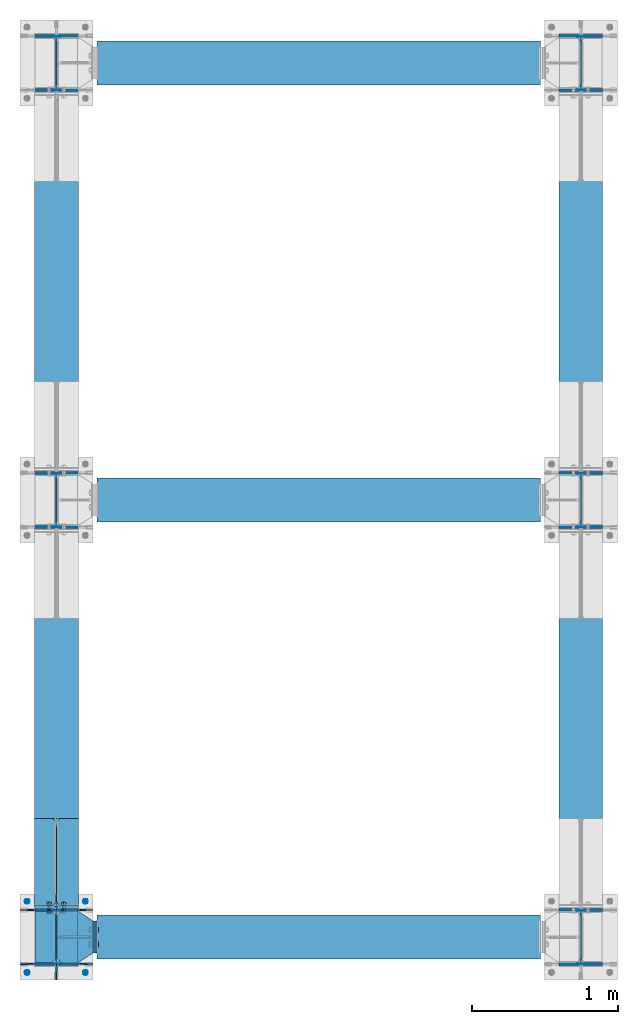
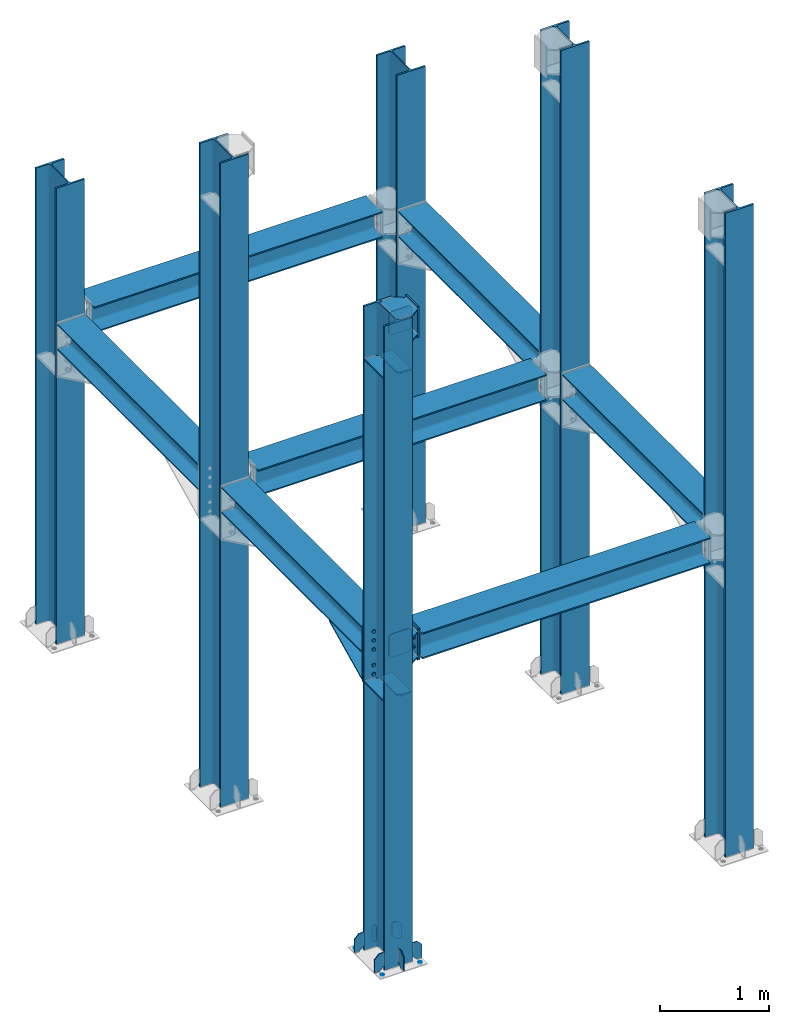
# One storey, part 1 of 23: 21 discrete accessories, 7 beams, 6 columns, 4 mechanical fasteners, 13 elements without a shape of their own.
"""IFC2X3 building model written with IfcOpenShell, lengths in millimetres."""

from ifc_helpers import new_model, si_unit, frame, origin_with_axes, origin_2d_with_axis, place, context, subcontext, project, spatial, polyline, circle, i_section, outline, extrude, clip, halfspace, source, transform, mapped, material, type_object, element, aggregate, save


model = new_model("IFC2X3")

# Units and contexts
model_context = context("Model", 3, precision=1e-05, world=origin_with_axes())
body_context = subcontext(model_context, "Body", "Model", "MODEL_VIEW")
ifc_project = project(units=[si_unit("LENGTHUNIT", "METRE", prefix="MILLI"), si_unit("AREAUNIT", "SQUARE_METRE"), si_unit("VOLUMEUNIT", "CUBIC_METRE"), si_unit("MASSUNIT", "GRAM", prefix="KILO"), si_unit("TIMEUNIT", "SECOND"), si_unit("PLANEANGLEUNIT", "RADIAN"), si_unit("SOLIDANGLEUNIT", "STERADIAN"), si_unit("THERMODYNAMICTEMPERATUREUNIT", "DEGREE_CELSIUS"), si_unit("LUMINOUSINTENSITYUNIT", "LUMEN")], contexts=[model_context])

# Site, building, storey
site_placement = place(None, origin_with_axes())
site = spatial("IfcSite", under=ifc_project, at=site_placement, CompositionType="ELEMENT")
building_placement = place(site_placement, origin_with_axes())
building = spatial("IfcBuilding", under=site, at=building_placement, Name="Edificio", CompositionType="ELEMENT")
storey_placement = place(building_placement, origin_with_axes())
storey = spatial("IfcBuildingStorey", under=building, at=storey_placement, Name="Livello 1", CompositionType="ELEMENT", Elevation=0.0)

# Assembly, column
assembly_1_placement = place(storey_placement, origin_with_axes())
assembly_1 = element("IfcElementAssembly", 1, at=assembly_1_placement, inside=storey, Name="COLUMN", AssemblyPlace="NOTDEFINED", PredefinedType="RIGID_FRAME")
ifc_material_1 = material(Name="STEEL/S235JR")
column_type = type_object("IfcColumnType", Name="HEA400", PredefinedType="NOTDEFINED")
column_1_placement = place(assembly_1_placement, frame((3600.0, 6000.0, 0.0), z_axis=(0.0, 0.0, 1.0), x_axis=(0.0, 1.0, 0.0)))
column_1 = element("IfcColumn", 2, at=column_1_placement, type_object=column_type, material=ifc_material_1, Name="COLUMN", ObjectType="HEA400", context=body_context, shape_type="Clipping", body=[
    clip(clip(extrude(i_section(OverallWidth=300.0, OverallDepth=390.0, WebThickness=11.0, FlangeThickness=19.0, FilletRadius=27.0, at=origin_2d_with_axis()), frame((0.0, 0.0, 5102.11580360386), z_axis=(0.0, 0.0, -1.0), x_axis=(0.0, 1.0, 0.0)), (0.0, 0.0, 1.0), 5092.12), halfspace(frame((-1000.0, 0.0, 5102.11580360386), z_axis=(0.0, 0.0, 1.0), x_axis=(0.0, 1.0, 0.0)), False)), halfspace(frame((-195.0, 0.0, 10.0), z_axis=(0.0, 0.0, 1.0), x_axis=(0.0, 1.0, 0.0)), True)),
])
aggregate(assembly_1, [column_1])

assembly_2_placement = place(storey_placement, origin_with_axes())
assembly_2 = element("IfcElementAssembly", 3, at=assembly_2_placement, inside=storey, Name="COLUMN", AssemblyPlace="NOTDEFINED", PredefinedType="RIGID_FRAME")
column_2_placement = place(assembly_2_placement, frame((0.0, 6000.0, 0.0), z_axis=(0.0, 0.0, 1.0), x_axis=(0.0, 1.0, 0.0)))
column_2 = element("IfcColumn", 4, at=column_2_placement, type_object=column_type, material=ifc_material_1, Name="COLUMN", ObjectType="HEA400", context=body_context, shape_type="Clipping", body=[
    clip(clip(extrude(i_section(OverallWidth=300.0, OverallDepth=390.0, WebThickness=11.0, FlangeThickness=19.0, FilletRadius=27.0, at=origin_2d_with_axis()), frame((0.0, 0.0, 5102.11580360386), z_axis=(0.0, 0.0, -1.0), x_axis=(0.0, 1.0, 0.0)), (0.0, 0.0, 1.0), 5092.12), halfspace(frame((-1000.0, 0.0, 5102.11580360386), z_axis=(0.0, 0.0, 1.0), x_axis=(0.0, 1.0, 0.0)), False)), halfspace(frame((-195.0, 0.0, 10.0), z_axis=(0.0, 0.0, 1.0), x_axis=(0.0, 1.0, 0.0)), True)),
])
aggregate(assembly_2, [column_2])

assembly_3_placement = place(storey_placement, origin_with_axes())
assembly_3 = element("IfcElementAssembly", 5, at=assembly_3_placement, inside=storey, Name="COLUMN", AssemblyPlace="NOTDEFINED", PredefinedType="RIGID_FRAME")
column_3_placement = place(assembly_3_placement, frame((3600.0, 3000.0, 0.0), z_axis=(0.0, 0.0, 1.0), x_axis=(0.0, 1.0, 0.0)))
column_3 = element("IfcColumn", 6, at=column_3_placement, type_object=column_type, material=ifc_material_1, Name="COLUMN", ObjectType="HEA400", context=body_context, shape_type="Clipping", body=[
    clip(extrude(i_section(OverallWidth=300.0, OverallDepth=390.0, WebThickness=11.0, FlangeThickness=19.0, FilletRadius=27.0, at=origin_2d_with_axis()), frame((0.0, 0.0, 7200.0), z_axis=(0.0, 0.0, -1.0), x_axis=(0.0, 1.0, 0.0)), (0.0, 0.0, 1.0), 7190.0), halfspace(frame((-195.0, 0.0, 10.0), z_axis=(0.0, 0.0, 1.0), x_axis=(0.0, 1.0, 0.0)), True)),
])
aggregate(assembly_3, [column_3])

assembly_4_placement = place(storey_placement, origin_with_axes())
assembly_4 = element("IfcElementAssembly", 7, at=assembly_4_placement, inside=storey, Name="COLUMN", AssemblyPlace="NOTDEFINED", PredefinedType="RIGID_FRAME")
column_4_placement = place(assembly_4_placement, frame((0.0, 3000.0, 0.0), z_axis=(0.0, 0.0, 1.0), x_axis=(0.0, 1.0, 0.0)))
column_4 = element("IfcColumn", 8, at=column_4_placement, type_object=column_type, material=ifc_material_1, Name="COLUMN", ObjectType="HEA400", context=body_context, shape_type="Clipping", body=[
    clip(extrude(i_section(OverallWidth=300.0, OverallDepth=390.0, WebThickness=11.0, FlangeThickness=19.0, FilletRadius=27.0, at=origin_2d_with_axis()), frame((0.0, 0.0, 7200.0), z_axis=(0.0, 0.0, -1.0), x_axis=(0.0, 1.0, 0.0)), (0.0, 0.0, 1.0), 7190.0), halfspace(frame((-195.0, 0.0, 10.0), z_axis=(0.0, 0.0, 1.0), x_axis=(0.0, 1.0, 0.0)), True)),
])
aggregate(assembly_4, [column_4])

assembly_5_placement = place(storey_placement, origin_with_axes())
assembly_5 = element("IfcElementAssembly", 9, at=assembly_5_placement, inside=storey, Name="COLUMN", AssemblyPlace="NOTDEFINED", PredefinedType="RIGID_FRAME")
column_5_placement = place(assembly_5_placement, frame((3600.0, 0.0, 0.0), z_axis=(0.0, 0.0, 1.0), x_axis=(0.0, 1.0, 0.0)))
column_5 = element("IfcColumn", 10, at=column_5_placement, type_object=column_type, material=ifc_material_1, Name="COLUMN", ObjectType="HEA400", context=body_context, shape_type="Clipping", body=[
    clip(extrude(i_section(OverallWidth=300.0, OverallDepth=390.0, WebThickness=11.0, FlangeThickness=19.0, FilletRadius=27.0, at=origin_2d_with_axis()), frame((0.0, 0.0, 7200.0), z_axis=(0.0, 0.0, -1.0), x_axis=(0.0, 1.0, 0.0)), (0.0, 0.0, 1.0), 7190.0), halfspace(frame((-195.0, 0.0, 10.0), z_axis=(0.0, 0.0, 1.0), x_axis=(0.0, 1.0, 0.0)), True)),
])
aggregate(assembly_5, [column_5])

assembly_6_placement = place(storey_placement, origin_with_axes())
assembly_6 = element("IfcElementAssembly", 11, at=assembly_6_placement, inside=storey, Name="COLUMN", AssemblyPlace="NOTDEFINED", PredefinedType="RIGID_FRAME")
column_6_placement = place(assembly_6_placement, frame((0.0, 0.0, 0.0), z_axis=(0.0, 0.0, 1.0), x_axis=(0.0, 1.0, 0.0)))
column_6 = element("IfcColumn", 12, at=column_6_placement, type_object=column_type, material=ifc_material_1, Name="COLUMN", ObjectType="HEA400", context=body_context, shape_type="Clipping", body=[
    clip(extrude(i_section(OverallWidth=300.0, OverallDepth=390.0, WebThickness=11.0, FlangeThickness=19.0, FilletRadius=27.0, at=origin_2d_with_axis()), frame((0.0, 0.0, 7200.0), z_axis=(0.0, 0.0, -1.0), x_axis=(0.0, 1.0, 0.0)), (0.0, 0.0, 1.0), 7190.0), halfspace(frame((-195.0, 0.0, 10.0), z_axis=(0.0, 0.0, 1.0), x_axis=(0.0, 1.0, 0.0)), True)),
])

# Assembly, beam
assembly_7_placement = place(storey_placement, origin_with_axes())
assembly_7 = element("IfcElementAssembly", 13, at=assembly_7_placement, inside=storey, Name="BEAM", AssemblyPlace="NOTDEFINED", PredefinedType="RIGID_FRAME")
beam_type = type_object("IfcBeamType", Name="HEA300", PredefinedType="NOTDEFINED")
beam_1_placement = place(assembly_7_placement, frame((0.0, 3000.0, 3455.0), z_axis=(0.0, 0.0, 1.0), x_axis=(0.0, -1.0, 0.0)))
beam_1 = element("IfcBeam", 14, at=beam_1_placement, type_object=beam_type, material=ifc_material_1, Name="BEAM", ObjectType="HEA300", context=body_context, shape_type="Clipping", body=[
    clip(clip(extrude(i_section(OverallWidth=300.0, OverallDepth=290.0, WebThickness=8.5, FlangeThickness=14.0, FilletRadius=27.0, at=origin_2d_with_axis()), frame((2785.0, 0.0, 0.0), z_axis=(-1.0, 0.0, 0.0), x_axis=(0.0, -1.0, 0.0)), (0.0, 0.0, 1.0), 2570.0), halfspace(frame((2785.0, 0.0, -145.0), z_axis=(-1.0, 0.0, 0.0), x_axis=(0.0, 1.0, 0.0)), True)), halfspace(frame((215.0, 0.0, -145.0), z_axis=(1.0, 0.0, 0.0), x_axis=(0.0, -1.0, 0.0)), True)),
])

assembly_8_placement = place(storey_placement, origin_with_axes())
assembly_8 = element("IfcElementAssembly", 15, at=assembly_8_placement, inside=storey, Name="BEAM", AssemblyPlace="NOTDEFINED", PredefinedType="RIGID_FRAME")
beam_2_placement = place(assembly_8_placement, frame((3600.0, 3000.0, 3455.0), z_axis=(0.0, 0.0, 1.0), x_axis=(0.0, -1.0, 0.0)))
beam_2 = element("IfcBeam", 16, at=beam_2_placement, type_object=beam_type, material=ifc_material_1, Name="BEAM", ObjectType="HEA300", context=body_context, shape_type="Clipping", body=[
    clip(clip(extrude(i_section(OverallWidth=300.0, OverallDepth=290.0, WebThickness=8.5, FlangeThickness=14.0, FilletRadius=27.0, at=origin_2d_with_axis()), frame((2785.0, 0.0, 0.0), z_axis=(-1.0, 0.0, 0.0), x_axis=(0.0, -1.0, 0.0)), (0.0, 0.0, 1.0), 2570.0), halfspace(frame((2785.0, 0.0, -145.0), z_axis=(-1.0, 0.0, 0.0), x_axis=(0.0, 1.0, 0.0)), True)), halfspace(frame((215.0, 0.0, -145.0), z_axis=(1.0, 0.0, 0.0), x_axis=(0.0, -1.0, 0.0)), True)),
])
aggregate(assembly_8, [beam_2])

assembly_9_placement = place(storey_placement, origin_with_axes())
assembly_9 = element("IfcElementAssembly", 17, at=assembly_9_placement, inside=storey, Name="BEAM", AssemblyPlace="NOTDEFINED", PredefinedType="RIGID_FRAME")
beam_3_placement = place(assembly_9_placement, frame((0.0, 6000.0, 3455.0), z_axis=(0.0, 0.0, 1.0), x_axis=(0.0, -1.0, 0.0)))
beam_3 = element("IfcBeam", 18, at=beam_3_placement, type_object=beam_type, material=ifc_material_1, Name="BEAM", ObjectType="HEA300", context=body_context, shape_type="Clipping", body=[
    clip(clip(extrude(i_section(OverallWidth=300.0, OverallDepth=290.0, WebThickness=8.5, FlangeThickness=14.0, FilletRadius=27.0, at=origin_2d_with_axis()), frame((2785.0, 0.0, 0.0), z_axis=(-1.0, 0.0, 0.0), x_axis=(0.0, -1.0, 0.0)), (0.0, 0.0, 1.0), 2570.0), halfspace(frame((2785.0, 0.0, -145.0), z_axis=(-1.0, 0.0, 0.0), x_axis=(0.0, 1.0, 0.0)), True)), halfspace(frame((215.0, 0.0, -145.0), z_axis=(1.0, 0.0, 0.0), x_axis=(0.0, -1.0, 0.0)), True)),
])
aggregate(assembly_9, [beam_3])

assembly_10_placement = place(storey_placement, origin_with_axes())
assembly_10 = element("IfcElementAssembly", 19, at=assembly_10_placement, inside=storey, Name="BEAM", AssemblyPlace="NOTDEFINED", PredefinedType="RIGID_FRAME")
beam_4_placement = place(assembly_10_placement, frame((3600.0, 6000.0, 3455.0), z_axis=(0.0, 0.0, 1.0), x_axis=(0.0, -1.0, 0.0)))
beam_4 = element("IfcBeam", 20, at=beam_4_placement, type_object=beam_type, material=ifc_material_1, Name="BEAM", ObjectType="HEA300", context=body_context, shape_type="Clipping", body=[
    clip(clip(extrude(i_section(OverallWidth=300.0, OverallDepth=290.0, WebThickness=8.5, FlangeThickness=14.0, FilletRadius=27.0, at=origin_2d_with_axis()), frame((2785.0, 0.0, 0.0), z_axis=(-1.0, 0.0, 0.0), x_axis=(0.0, -1.0, 0.0)), (0.0, 0.0, 1.0), 2570.0), halfspace(frame((2785.0, 0.0, -145.0), z_axis=(-1.0, 0.0, 0.0), x_axis=(0.0, 1.0, 0.0)), True)), halfspace(frame((215.0, 0.0, -145.0), z_axis=(1.0, 0.0, 0.0), x_axis=(0.0, -1.0, 0.0)), True)),
])
aggregate(assembly_10, [beam_4])

assembly_11_placement = place(storey_placement, origin_with_axes())
assembly_11 = element("IfcElementAssembly", 21, at=assembly_11_placement, inside=storey, Name="BEAM", AssemblyPlace="NOTDEFINED", PredefinedType="RIGID_FRAME")
beam_5_placement = place(assembly_11_placement, frame((0.0, 6000.0, 3455.0), z_axis=(0.0, 0.0, 1.0), x_axis=(1.0, 0.0, 0.0)))
beam_5 = element("IfcBeam", 22, at=beam_5_placement, type_object=beam_type, material=ifc_material_1, Name="BEAM", ObjectType="HEA300", context=body_context, shape_type="Clipping", body=[
    clip(clip(extrude(i_section(OverallWidth=300.0, OverallDepth=290.0, WebThickness=8.5, FlangeThickness=14.0, FilletRadius=27.0, at=origin_2d_with_axis()), frame((3322.0, 0.0, 0.0), z_axis=(-1.0, 0.0, 0.0), x_axis=(0.0, -1.0, 0.0)), (0.0, 0.0, 1.0), 3044.0), halfspace(frame((3322.0, -150.0, 0.0), z_axis=(1.0, 0.0, 0.0), x_axis=(0.0, 0.0, 1.0)), False)), halfspace(frame((278.0, 150.0, 0.0), z_axis=(-1.0, 0.0, 0.0), x_axis=(0.0, 0.0, 1.0)), False)),
])
aggregate(assembly_11, [beam_5])

assembly_12_placement = place(storey_placement, origin_with_axes())
assembly_12 = element("IfcElementAssembly", 23, at=assembly_12_placement, inside=storey, Name="BEAM", AssemblyPlace="NOTDEFINED", PredefinedType="RIGID_FRAME")
beam_6_placement = place(assembly_12_placement, frame((0.0, 3000.0, 3455.0), z_axis=(0.0, 0.0, 1.0), x_axis=(1.0, 0.0, 0.0)))
beam_6 = element("IfcBeam", 24, at=beam_6_placement, type_object=beam_type, material=ifc_material_1, Name="BEAM", ObjectType="HEA300", context=body_context, shape_type="Clipping", body=[
    clip(clip(extrude(i_section(OverallWidth=300.0, OverallDepth=290.0, WebThickness=8.5, FlangeThickness=14.0, FilletRadius=27.0, at=origin_2d_with_axis()), frame((3322.0, 0.0, 0.0), z_axis=(-1.0, 0.0, 0.0), x_axis=(0.0, -1.0, 0.0)), (0.0, 0.0, 1.0), 3044.0), halfspace(frame((3322.0, -150.0, 0.0), z_axis=(1.0, 0.0, 0.0), x_axis=(0.0, 0.0, 1.0)), False)), halfspace(frame((278.0, 150.0, 0.0), z_axis=(-1.0, 0.0, 0.0), x_axis=(0.0, 0.0, 1.0)), False)),
])
aggregate(assembly_12, [beam_6])

assembly_13_placement = place(storey_placement, origin_with_axes())
assembly_13 = element("IfcElementAssembly", 25, at=assembly_13_placement, inside=storey, Name="BEAM", AssemblyPlace="NOTDEFINED", PredefinedType="RIGID_FRAME")
beam_7_placement = place(assembly_13_placement, frame((0.0, 0.0, 3455.0), z_axis=(0.0, 0.0, 1.0), x_axis=(1.0, 0.0, 0.0)))
beam_7 = element("IfcBeam", 26, at=beam_7_placement, type_object=beam_type, material=ifc_material_1, Name="BEAM", ObjectType="HEA300", context=body_context, shape_type="Clipping", body=[
    clip(clip(extrude(i_section(OverallWidth=300.0, OverallDepth=290.0, WebThickness=8.5, FlangeThickness=14.0, FilletRadius=27.0, at=origin_2d_with_axis()), frame((3322.0, 0.0, 0.0), z_axis=(-1.0, 0.0, 0.0), x_axis=(0.0, -1.0, 0.0)), (0.0, 0.0, 1.0), 3044.0), halfspace(frame((3322.0, -150.0, 0.0), z_axis=(1.0, 0.0, 0.0), x_axis=(0.0, 0.0, 1.0)), False)), halfspace(frame((278.0, 150.0, 0.0), z_axis=(-1.0, 0.0, 0.0), x_axis=(0.0, 0.0, 1.0)), False)),
])

# Discrete accessory
discrete_accessory_type_1 = type_object("IfcDiscreteAccessoryType", Name="PIATTO")
discrete_accessory_1_placement = place(assembly_6_placement, frame((145.5, 175.999999999747, 3003.49718304324), z_axis=(0.0, 0.0, 1.0), x_axis=(-1.0, 0.0, 0.0)))
discrete_accessory_1 = element("IfcDiscreteAccessory", 27, at=discrete_accessory_1_placement, type_object=discrete_accessory_type_1, material=ifc_material_1, Name="PIATTO", context=body_context, shape_type="SweptSolid", body=[
    extrude(outline(polyline([(0.0, 0.0), (113.0, 0.0), (140.0, 27.0), (140.0, 325.0), (113.0, 352.0), (0.0, 352.0), (0.0, 0.0)])), frame((0.0, 0.0, -10.0), z_axis=(0.0, 0.0, 1.0), x_axis=(1.0, 0.0, 0.0)), (0.0, 0.0, 1.0), 20.0),
])

discrete_accessory_2_placement = place(assembly_6_placement, frame((-145.5, 175.999999999747, 3003.49718304324), z_axis=(0.0, 0.0, -1.0), x_axis=(1.0, 0.0, 0.0)))
discrete_accessory_2 = element("IfcDiscreteAccessory", 28, at=discrete_accessory_2_placement, type_object=discrete_accessory_type_1, material=ifc_material_1, Name="PIATTO", context=body_context, shape_type="SweptSolid", body=[
    extrude(outline(polyline([(0.0, 0.0), (113.0, 0.0), (140.0, 27.0), (140.0, 325.0), (113.0, 352.0), (0.0, 352.0), (0.0, 0.0)])), frame((0.0, 0.0, -10.0), z_axis=(0.0, 0.0, 1.0), x_axis=(1.0, 0.0, 0.0)), (0.0, 0.0, 1.0), 20.0),
])

discrete_accessory_3_placement = place(assembly_7_placement, frame((0.0, 204.99999999962, 2993.20494914513), z_axis=(0.0, 1.0, 0.0), x_axis=(0.0, 0.0, 1.0)))
discrete_accessory_3 = element("IfcDiscreteAccessory", 29, at=discrete_accessory_3_placement, type_object=discrete_accessory_type_1, material=ifc_material_1, Name="PIATTO", context=body_context, shape_type="SweptSolid", body=[
    extrude(outline(polyline([(0.0, -150.0), (0.0, 150.0), (616.795050854866, 150.0), (616.795050854866, -150.0), (0.0, -150.0)])), frame((0.0, 0.0, -10.0), z_axis=(0.0, 0.0, 1.0), x_axis=(1.0, 0.0, 0.0)), (0.0, 0.0, 1.0), 20.0),
])

discrete_accessory_4_placement = place(assembly_6_placement, frame((145.5, 176.0000000003, 6603.4971830433), z_axis=(0.0, 0.0, 1.0), x_axis=(-1.0, 0.0, 0.0)))
discrete_accessory_4 = element("IfcDiscreteAccessory", 30, at=discrete_accessory_4_placement, type_object=discrete_accessory_type_1, material=ifc_material_1, Name="PIATTO", context=body_context, shape_type="SweptSolid", body=[
    extrude(outline(polyline([(0.0, 0.0), (113.0, 0.0), (140.0, 27.0), (140.0, 325.0), (113.0, 352.0), (0.0, 352.0), (0.0, 0.0)])), frame((0.0, 0.0, -10.0), z_axis=(0.0, 0.0, 1.0), x_axis=(1.0, 0.0, 0.0)), (0.0, 0.0, 1.0), 20.0),
])

discrete_accessory_5_placement = place(assembly_6_placement, frame((-145.5, 176.0000000003, 6603.4971830433), z_axis=(0.0, 0.0, -1.0), x_axis=(1.0, 0.0, 0.0)))
discrete_accessory_5 = element("IfcDiscreteAccessory", 31, at=discrete_accessory_5_placement, type_object=discrete_accessory_type_1, material=ifc_material_1, Name="PIATTO", context=body_context, shape_type="SweptSolid", body=[
    extrude(outline(polyline([(0.0, 0.0), (113.0, 0.0), (140.0, 27.0), (140.0, 325.0), (113.0, 352.0), (0.0, 352.0), (0.0, 0.0)])), frame((0.0, 0.0, -10.0), z_axis=(0.0, 0.0, 1.0), x_axis=(1.0, 0.0, 0.0)), (0.0, 0.0, 1.0), 20.0),
])

discrete_accessory_6_placement = place(assembly_6_placement, frame((150.0, -185.5, 60.0), z_axis=(0.0, -1.0, 0.0), x_axis=(0.707106781186547, 0.0, -0.707106781186548)))
discrete_accessory_6 = element("IfcDiscreteAccessory", 32, at=discrete_accessory_6_placement, type_object=discrete_accessory_type_1, material=ifc_material_1, Name="PIATTO", context=body_context, shape_type="SweptSolid", body=[
    extrude(outline(polyline([(0.0, 0.0), (70.7106781005862, 2.8705926524708e-12), (106.06601715088, 35.3553390502979), (4.2348347051302e-12, 141.421356201177), (-70.7106781005827, 141.421356201174), (-106.066017150877, 106.066017150879), (0.0, 0.0)])), frame((0.0, 0.0, -5.0), z_axis=(0.0, 0.0, 1.0), x_axis=(1.0, 0.0, 0.0)), (0.0, 0.0, 1.0), 10.0),
])

discrete_accessory_7_placement = place(assembly_6_placement, frame((150.0, 185.5, 60.0), z_axis=(0.0, -1.0, 0.0), x_axis=(0.707106781186547, 0.0, -0.707106781186548)))
discrete_accessory_7 = element("IfcDiscreteAccessory", 33, at=discrete_accessory_7_placement, type_object=discrete_accessory_type_1, material=ifc_material_1, Name="PIATTO", context=body_context, shape_type="SweptSolid", body=[
    extrude(outline(polyline([(0.0, 0.0), (70.7106781005862, 2.8705926524708e-12), (106.06601715088, 35.3553390502979), (4.2348347051302e-12, 141.421356201177), (-70.7106781005827, 141.421356201174), (-106.066017150877, 106.066017150879), (0.0, 0.0)])), frame((0.0, 0.0, -5.0), z_axis=(0.0, 0.0, 1.0), x_axis=(1.0, 0.0, 0.0)), (0.0, 0.0, 1.0), 10.0),
])

discrete_accessory_8_placement = place(assembly_6_placement, frame((-150.0, 185.5, 60.0), z_axis=(0.0, 1.0, 0.0), x_axis=(-0.707106781186547, 0.0, -0.707106781186548)))
discrete_accessory_8 = element("IfcDiscreteAccessory", 34, at=discrete_accessory_8_placement, type_object=discrete_accessory_type_1, material=ifc_material_1, Name="PIATTO", context=body_context, shape_type="SweptSolid", body=[
    extrude(outline(polyline([(0.0, 0.0), (70.7106781005862, 2.8705926524708e-12), (106.06601715088, 35.3553390502979), (4.2348347051302e-12, 141.421356201177), (-70.7106781005827, 141.421356201174), (-106.066017150877, 106.066017150879), (0.0, 0.0)])), frame((0.0, 0.0, -5.0), z_axis=(0.0, 0.0, 1.0), x_axis=(1.0, 0.0, 0.0)), (0.0, 0.0, 1.0), 10.0),
])

discrete_accessory_9_placement = place(assembly_6_placement, frame((-150.0, -185.5, 60.0), z_axis=(0.0, 1.0, 0.0), x_axis=(-0.707106781186547, 0.0, -0.707106781186548)))
discrete_accessory_9 = element("IfcDiscreteAccessory", 35, at=discrete_accessory_9_placement, type_object=discrete_accessory_type_1, material=ifc_material_1, Name="PIATTO", context=body_context, shape_type="SweptSolid", body=[
    extrude(outline(polyline([(0.0, 0.0), (70.7106781005862, 2.8705926524708e-12), (106.06601715088, 35.3553390502979), (4.2348347051302e-12, 141.421356201177), (-70.7106781005827, 141.421356201174), (-106.066017150877, 106.066017150879), (0.0, 0.0)])), frame((0.0, 0.0, -5.0), z_axis=(0.0, 0.0, 1.0), x_axis=(1.0, 0.0, 0.0)), (0.0, 0.0, 1.0), 10.0),
])

discrete_accessory_10_placement = place(assembly_6_placement, frame((0.0, -195.0, 60.0), z_axis=(-1.0, 0.0, 0.0), x_axis=(0.0, -0.707106781186547, -0.707106781186548)))
discrete_accessory_10 = element("IfcDiscreteAccessory", 36, at=discrete_accessory_10_placement, type_object=discrete_accessory_type_1, material=ifc_material_1, Name="PIATTO", context=body_context, shape_type="SweptSolid", body=[
    extrude(outline(polyline([(0.0, 0.0), (70.7106781005862, 2.8705926524708e-12), (106.06601715088, 35.3553390502979), (4.2348347051302e-12, 141.421356201177), (-70.7106781005827, 141.421356201174), (-106.066017150877, 106.066017150879), (0.0, 0.0)])), frame((0.0, 0.0, -5.0), z_axis=(0.0, 0.0, 1.0), x_axis=(1.0, 0.0, 0.0)), (0.0, 0.0, 1.0), 10.0),
])

discrete_accessory_11_placement = place(assembly_6_placement, frame((0.0, 195.0, 60.0), z_axis=(1.0, 0.0, 0.0), x_axis=(0.0, 0.707106781186547, -0.707106781186548)))
discrete_accessory_11 = element("IfcDiscreteAccessory", 37, at=discrete_accessory_11_placement, type_object=discrete_accessory_type_1, material=ifc_material_1, Name="PIATTO", context=body_context, shape_type="SweptSolid", body=[
    extrude(outline(polyline([(0.0, 0.0), (70.7106781005862, 2.8705926524708e-12), (106.06601715088, 35.3553390502979), (4.2348347051302e-12, 141.421356201177), (-70.7106781005827, 141.421356201174), (-106.066017150877, 106.066017150879), (0.0, 0.0)])), frame((0.0, 0.0, -5.0), z_axis=(0.0, 0.0, 1.0), x_axis=(1.0, 0.0, 0.0)), (0.0, 0.0, 1.0), 10.0),
])

# Mechanical fastener
ifc_material_2 = material(Name="HR")
discrete_accessory_type_2 = type_object("IfcDiscreteAccessoryType", Name="Bolt assembly")
shared_shape_1 = source(origin_with_axes(), body_context, "Body", "SweptSolid", [
    extrude(circle(Radius=11.0, at=origin_2d_with_axis()), frame((0.0, 13.9, 0.0), z_axis=(0.0, 1.0, 0.0), x_axis=(1.0, 0.0, 0.0)), (0.0, 0.0, 1.0), 14.1),
    extrude(circle(Radius=11.0, at=origin_2d_with_axis()), frame((0.0, 0.1, 0.0), z_axis=(0.0, 1.0, 0.0), x_axis=(1.0, 0.0, 0.0)), (0.0, 0.0, 1.0), 14.0),
    extrude(outline(polyline([(18.47520861408, 0.0), (9.23760430704, 16.0000000000023), (-9.23760430704, 16.0000000000023), (-18.47520861408, 0.0), (-9.23760430704, -16.0000000000023), (9.23760430704, -16.0000000000023), (18.47520861408, 0.0)])), frame((0.0, -12.5, 0.0), z_axis=(0.0, 1.0, 0.0), x_axis=(1.0, 0.0, 0.0)), (0.0, 0.0, 1.0), 12.5),
    extrude(circle(Radius=10.0, at=origin_2d_with_axis()), frame((0.0, 0.0, 0.0), z_axis=(0.0, 1.0, 0.0), x_axis=(1.0, 0.0, 0.0)), (0.0, 0.0, 1.0), 55.0),
    extrude(circle(Radius=18.5, at=origin_2d_with_axis()), frame((0.0, 28.0, 0.0), z_axis=(0.0, 1.0, 0.0), x_axis=(1.0, 0.0, 0.0)), (0.0, 0.0, 1.0), 4.0),
    extrude(outline(polyline([(18.47520861408, 0.0), (9.23760430704, 16.0000000000023), (-9.23760430704, 16.0000000000023), (-18.47520861408, 0.0), (-9.23760430704, -16.0000000000023), (9.23760430704, -16.0000000000023), (18.47520861408, 0.0)])), frame((0.0, 32.0, 0.0), z_axis=(0.0, 1.0, 0.0), x_axis=(1.0, 0.0, 0.0)), (0.0, 0.0, 1.0), 18.0),
])
mechanical_fastener_1_placement = place(assembly_13_placement, frame((278.0, -50.0, 3405.0), z_axis=(0.0, 0.0, 1.0), x_axis=(0.0, 1.0, 0.0)))
mechanical_fastener_1 = element("IfcMechanicalFastener", 38, at=mechanical_fastener_1_placement, type_object=discrete_accessory_type_2, material=ifc_material_2, Name="Bolt assembly", NominalDiameter=20.0, NominalLength=55.0, context=body_context, shape_type="MappedRepresentation", body=[
    mapped(shared_shape_1, transform((0.0, 0.0, 0.0))),
    mapped(shared_shape_1, transform((100.0, 0.0, 0.0))),
    mapped(shared_shape_1, transform((0.0, 0.0, 100.0))),
    mapped(shared_shape_1, transform((100.0, 0.0, 100.0))),
])

# Discrete accessory
discrete_accessory_type_3 = type_object("IfcDiscreteAccessoryType", Name="MIDDLE_PLATE")
discrete_accessory_12_placement = place(assembly_6_placement, frame((250.0, 0.0, 3586.0), z_axis=(0.0, -1.0, 0.0), x_axis=(-1.0, 0.0, 0.0)))
discrete_accessory_12 = element("IfcDiscreteAccessory", 39, at=discrete_accessory_12_placement, type_object=discrete_accessory_type_3, material=ifc_material_1, Name="MIDDLE_PLATE", context=body_context, shape_type="SweptSolid", body=[
    extrude(outline(polyline([(0.0, 30.0), (30.0, 0.0), (214.5, 0.0), (244.5, 30.0), (244.5, 232.0), (214.5, 262.0), (30.0, 262.0), (0.0, 232.0), (0.0, 30.0)])), frame((0.0, 0.0, -7.0), z_axis=(0.0, 0.0, 1.0), x_axis=(1.0, 0.0, 0.0)), (0.0, 0.0, 1.0), 14.0),
])

discrete_accessory_13_placement = place(assembly_6_placement, frame((250.0, 0.0, 7186.0), z_axis=(0.0, -1.0, 0.0), x_axis=(-1.0, 0.0, 0.0)))
discrete_accessory_13 = element("IfcDiscreteAccessory", 40, at=discrete_accessory_13_placement, type_object=discrete_accessory_type_3, material=ifc_material_1, Name="MIDDLE_PLATE", context=body_context, shape_type="SweptSolid", body=[
    extrude(outline(polyline([(0.0, 30.0), (30.0, 0.0), (214.5, 0.0), (244.5, 30.0), (244.5, 232.0), (214.5, 262.0), (30.0, 262.0), (0.0, 232.0), (0.0, 30.0)])), frame((0.0, 0.0, -7.0), z_axis=(0.0, 0.0, 1.0), x_axis=(1.0, 0.0, 0.0)), (0.0, 0.0, 1.0), 14.0),
])

discrete_accessory_type_4 = type_object("IfcDiscreteAccessoryType", Name="BOTTOM_PLATE")
discrete_accessory_14_placement = place(assembly_6_placement, frame((5.5, 176.0, 3317.0), z_axis=(0.0, 0.0, 1.0), x_axis=(0.0, -1.0, 0.0)))
discrete_accessory_14 = element("IfcDiscreteAccessory", 41, at=discrete_accessory_14_placement, type_object=discrete_accessory_type_4, material=ifc_material_1, Name="BOTTOM_PLATE", context=body_context, shape_type="SweptSolid", body=[
    extrude(outline(polyline([(0.0, 30.0), (30.0, 0.0), (322.0, 0.0), (352.0, 30.0), (352.0, 144.5), (286.0, 244.5), (66.0, 244.5), (0.0, 144.5), (0.0, 30.0)])), frame((0.0, 0.0, -7.0), z_axis=(0.0, 0.0, 1.0), x_axis=(1.0, 0.0, 0.0)), (0.0, 0.0, 1.0), 14.0),
])

discrete_accessory_15_placement = place(assembly_6_placement, frame((5.5, 176.0, 6917.0), z_axis=(0.0, 0.0, 1.0), x_axis=(0.0, -1.0, 0.0)))
discrete_accessory_15 = element("IfcDiscreteAccessory", 42, at=discrete_accessory_15_placement, type_object=discrete_accessory_type_4, material=ifc_material_1, Name="BOTTOM_PLATE", context=body_context, shape_type="SweptSolid", body=[
    extrude(outline(polyline([(0.0, 30.0), (30.0, 0.0), (322.0, 0.0), (352.0, 30.0), (352.0, 144.5), (286.0, 244.5), (66.0, 244.5), (0.0, 144.5), (0.0, 30.0)])), frame((0.0, 0.0, -7.0), z_axis=(0.0, 0.0, 1.0), x_axis=(1.0, 0.0, 0.0)), (0.0, 0.0, 1.0), 14.0),
])

discrete_accessory_type_5 = type_object("IfcDiscreteAccessoryType", Name="TOP_PLATE")
discrete_accessory_16_placement = place(assembly_6_placement, frame((150.0, 176.0, 3593.0), z_axis=(0.0, 0.0, 1.0), x_axis=(-1.0, 0.0, 0.0)))
discrete_accessory_16 = element("IfcDiscreteAccessory", 43, at=discrete_accessory_16_placement, type_object=discrete_accessory_type_5, material=ifc_material_1, Name="TOP_PLATE", context=body_context, shape_type="SweptSolid", body=[
    extrude(outline(polyline([(0.0, 0.0), (114.5, 0.0), (144.5, 30.0), (144.5, 322.0), (114.5, 352.0), (0.0, 352.0), (-100.0, 286.0), (-100.0, 66.0), (0.0, 0.0)])), frame((0.0, 0.0, -7.0), z_axis=(0.0, 0.0, 1.0), x_axis=(1.0, 0.0, 0.0)), (0.0, 0.0, 1.0), 14.0),
])

discrete_accessory_17_placement = place(assembly_6_placement, frame((150.0, 176.0, 7193.0), z_axis=(0.0, 0.0, 1.0), x_axis=(-1.0, 0.0, 0.0)))
discrete_accessory_17 = element("IfcDiscreteAccessory", 44, at=discrete_accessory_17_placement, type_object=discrete_accessory_type_5, material=ifc_material_1, Name="TOP_PLATE", context=body_context, shape_type="SweptSolid", body=[
    extrude(outline(polyline([(0.0, 0.0), (114.5, 0.0), (144.5, 30.0), (144.5, 322.0), (114.5, 352.0), (0.0, 352.0), (-100.0, 286.0), (-100.0, 66.0), (0.0, 0.0)])), frame((0.0, 0.0, -7.0), z_axis=(0.0, 0.0, 1.0), x_axis=(1.0, 0.0, 0.0)), (0.0, 0.0, 1.0), 14.0),
])

discrete_accessory_type_6 = type_object("IfcDiscreteAccessoryType", Name="ENDPLATE_2")
discrete_accessory_18_placement = place(assembly_13_placement, frame((271.0, 110.0, 3280.0), z_axis=(1.0, 0.0, 0.0), x_axis=(0.0, 0.0, 1.0)))
discrete_accessory_18 = element("IfcDiscreteAccessory", 45, at=discrete_accessory_18_placement, type_object=discrete_accessory_type_6, material=ifc_material_1, Name="ENDPLATE_2", context=body_context, shape_type="SweptSolid", body=[
    extrude(outline(polyline([(0.0, 0.0), (350.0, 0.0), (350.0, 220.0), (0.0, 220.0), (0.0, 0.0)])), frame((0.0, 0.0, -7.0), z_axis=(0.0, 0.0, 1.0), x_axis=(1.0, 0.0, 0.0)), (0.0, 0.0, 1.0), 14.0),
])

aggregate(assembly_13, [mechanical_fastener_1, discrete_accessory_18, beam_7])

discrete_accessory_type_7 = type_object("IfcDiscreteAccessoryType", Name="ENDPLATE_1")
discrete_accessory_19_placement = place(assembly_6_placement, frame((257.0, 110.0, 3280.0), z_axis=(1.0, 0.0, 0.0), x_axis=(0.0, 0.0, 1.0)))
discrete_accessory_19 = element("IfcDiscreteAccessory", 46, at=discrete_accessory_19_placement, type_object=discrete_accessory_type_7, material=ifc_material_1, Name="ENDPLATE_1", context=body_context, shape_type="SweptSolid", body=[
    extrude(outline(polyline([(0.0, 0.0), (350.0, 0.0), (350.0, 220.0), (0.0, 220.0), (0.0, 0.0)])), frame((0.0, 0.0, -7.0), z_axis=(0.0, 0.0, 1.0), x_axis=(1.0, 0.0, 0.0)), (0.0, 0.0, 1.0), 14.0),
])

discrete_accessory_20_placement = place(assembly_6_placement, frame((257.0, 110.0, 6880.0), z_axis=(1.0, 0.0, 0.0), x_axis=(0.0, 0.0, 1.0)))
discrete_accessory_20 = element("IfcDiscreteAccessory", 47, at=discrete_accessory_20_placement, type_object=discrete_accessory_type_7, material=ifc_material_1, Name="ENDPLATE_1", context=body_context, shape_type="SweptSolid", body=[
    extrude(outline(polyline([(0.0, 0.0), (350.0, 0.0), (350.0, 220.0), (0.0, 220.0), (0.0, 0.0)])), frame((0.0, 0.0, -7.0), z_axis=(0.0, 0.0, 1.0), x_axis=(1.0, 0.0, 0.0)), (0.0, 0.0, 1.0), 14.0),
])

# Mechanical fastener
shared_shape_2 = source(origin_with_axes(), body_context, "Body", "SweptSolid", [
    extrude(circle(Radius=11.0, at=origin_2d_with_axis()), frame((0.0, -19.9000000006085, 0.0), z_axis=(0.0, 1.0, 0.0), x_axis=(1.0, 0.0, 0.0)), (0.0, 0.0, 1.0), 19.0),
    extrude(circle(Radius=11.0, at=origin_2d_with_axis()), frame((0.0, -1.10000000013006, 0.0), z_axis=(0.0, 1.0, 0.0), x_axis=(1.0, 0.0, 0.0)), (0.0, 0.0, 1.0), 20.1),
    extrude(outline(polyline([(18.47520861408, 0.0), (9.23760430704, 16.0000000000023), (-9.23760430704, 16.0000000000023), (-18.47520861408, 0.0), (-9.23760430704, -16.0000000000023), (9.23760430704, -16.0000000000023), (18.47520861408, 0.0)])), frame((0.0, -32.5000000006085, 0.0), z_axis=(0.0, 1.0, 0.0), x_axis=(1.0, 0.0, 0.0)), (0.0, 0.0, 1.0), 12.5),
    extrude(circle(Radius=10.0, at=origin_2d_with_axis()), frame((0.0, -20.0000000006085, 0.0), z_axis=(0.0, 1.0, 0.0), x_axis=(1.0, 0.0, 0.0)), (0.0, 0.0, 1.0), 65.0),
    extrude(circle(Radius=18.5, at=origin_2d_with_axis()), frame((0.0, 18.9999999998699, 0.0), z_axis=(0.0, 1.0, 0.0), x_axis=(1.0, 0.0, 0.0)), (0.0, 0.0, 1.0), 4.0),
    extrude(outline(polyline([(18.47520861408, 0.0), (9.23760430704, 16.0000000000023), (-9.23760430704, 16.0000000000023), (-18.47520861408, 0.0), (-9.23760430704, -16.0000000000023), (9.23760430704, -16.0000000000023), (18.47520861408, 0.0)])), frame((0.0, 22.9999999998699, 0.0), z_axis=(0.0, 1.0, 0.0), x_axis=(1.0, 0.0, 0.0)), (0.0, 0.0, 1.0), 18.0),
])
mechanical_fastener_2_placement = place(assembly_7_placement, frame((0.0, 195.999999999778, 3063.20494914513), z_axis=(-1.0, 0.0, 0.0), x_axis=(0.0, 0.0, 1.0)))
mechanical_fastener_2 = element("IfcMechanicalFastener", 48, at=mechanical_fastener_2_placement, type_object=discrete_accessory_type_2, material=ifc_material_2, Name="Bolt assembly", NominalDiameter=20.0, NominalLength=65.0, context=body_context, shape_type="MappedRepresentation", body=[
    mapped(shared_shape_2, transform((0.0, 0.0, -50.0))),
    mapped(shared_shape_2, transform((0.0, 0.0, 50.0))),
    mapped(shared_shape_2, transform((100.0, 0.0, -50.0))),
    mapped(shared_shape_2, transform((100.0, 0.0, 50.0))),
])

mechanical_fastener_3_placement = place(assembly_7_placement, frame((0.0, 195.999999999998, 3540.00000000001), z_axis=(1.0, 0.0, 0.0), x_axis=(0.0, 0.0, -1.0)))
mechanical_fastener_3 = element("IfcMechanicalFastener", 49, at=mechanical_fastener_3_placement, type_object=discrete_accessory_type_2, material=ifc_material_2, Name="Bolt assembly", NominalDiameter=20.0, NominalLength=65.0, context=body_context, shape_type="MappedRepresentation", body=[
    mapped(shared_shape_2, transform((0.0, 0.0, -50.0))),
    mapped(shared_shape_2, transform((0.0, 0.0, 50.0))),
    mapped(shared_shape_2, transform((100.0, 0.0, -50.0))),
    mapped(shared_shape_2, transform((100.0, 0.0, 50.0))),
    mapped(shared_shape_2, transform((200.0, 0.0, -50.0))),
    mapped(shared_shape_2, transform((200.0, 0.0, 50.0))),
])

# Discrete accessory
discrete_accessory_type_8 = type_object("IfcDiscreteAccessoryType")
discrete_accessory_21_placement = place(assembly_7_placement, frame((-3.37507799486048e-12, 151.683333333347, 3133.65033895337), z_axis=(0.0, -0.436666666931657, 0.8996233778592), x_axis=(0.0, 0.8996233778592, 0.436666666931657)))
discrete_accessory_21 = element("IfcDiscreteAccessory", 50, at=discrete_accessory_21_placement, type_object=discrete_accessory_type_8, material=ifc_material_1, ObjectType="HEA300", context=body_context, shape_type="Clipping", body=[
    clip(clip(clip(clip(extrude(i_section(OverallWidth=300.0, OverallDepth=290.0, WebThickness=8.5, FlangeThickness=14.0, FilletRadius=27.0, at=origin_2d_with_axis()), frame((1079.68937216795, 0.0, 0.0), z_axis=(-1.0, 0.0, 0.0), x_axis=(0.0, -1.0, 0.0)), (0.0, 0.0, 1.0), 1351.67), halfspace(frame((105.124285258009, 150.0, 145.000000000002), z_axis=(0.436666666931658, 0.0, 0.8996233778592), x_axis=(0.8996233778592, 0.0, -0.436666666931658)), False)), halfspace(frame((6.79543622875235, 150.0, -144.999999999998), z_axis=(-1.0, 0.0, 0.0), x_axis=(0.0, 0.0, 1.0)), False)), halfspace(frame((666.945762685627, 4.18367562815547e-11, -145.000000196482), z_axis=(0.8996233778592, 0.0, -0.436666666931658), x_axis=(0.0, -1.0, 0.0)), False)), halfspace(frame((697.267172587419, 4.18367562815547e-11, 1291.51415739888), z_axis=(-0.8996233778592, 0.0, 0.436666666931657), x_axis=(0.0, -1.0, 0.0)), False)),
])

aggregate(assembly_7, [mechanical_fastener_2, mechanical_fastener_3, discrete_accessory_3, discrete_accessory_21, beam_1])

# Mechanical fastener
shared_shape_3 = source(origin_with_axes(), body_context, "Body", "SweptSolid", [
    extrude(circle(Radius=16.0, at=origin_2d_with_axis()), frame((0.0, 0.0, 0.0), z_axis=(0.0, 1.0, 0.0), x_axis=(1.0, 0.0, 0.0)), (0.0, 0.0, 1.0), 10.1),
])
mechanical_fastener_4_placement = place(assembly_6_placement, frame((0.0, 195.0, 10.0), z_axis=(1.0, 0.0, 0.0), x_axis=(0.0, -1.0, 0.0)))
mechanical_fastener_4 = element("IfcMechanicalFastener", 51, at=mechanical_fastener_4_placement, type_object=discrete_accessory_type_2, material=ifc_material_2, Name="Bolt assembly", NominalDiameter=20.0, NominalLength=10.0, context=body_context, shape_type="MappedRepresentation", body=[
    mapped(shared_shape_3, transform((-50.0, 0.0, -200.0))),
    mapped(shared_shape_3, transform((-50.0, 0.0, 200.0))),
    mapped(shared_shape_3, transform((440.0, 0.0, -200.0))),
    mapped(shared_shape_3, transform((440.0, 0.0, 200.0))),
])

aggregate(assembly_6, [discrete_accessory_12, discrete_accessory_14, discrete_accessory_16, discrete_accessory_19, discrete_accessory_1, discrete_accessory_2, discrete_accessory_13, discrete_accessory_15, discrete_accessory_17, discrete_accessory_20, discrete_accessory_4, discrete_accessory_5, discrete_accessory_6, discrete_accessory_7, discrete_accessory_8, discrete_accessory_9, discrete_accessory_10, discrete_accessory_11, mechanical_fastener_4, column_6])

save(model, "model.ifc")
